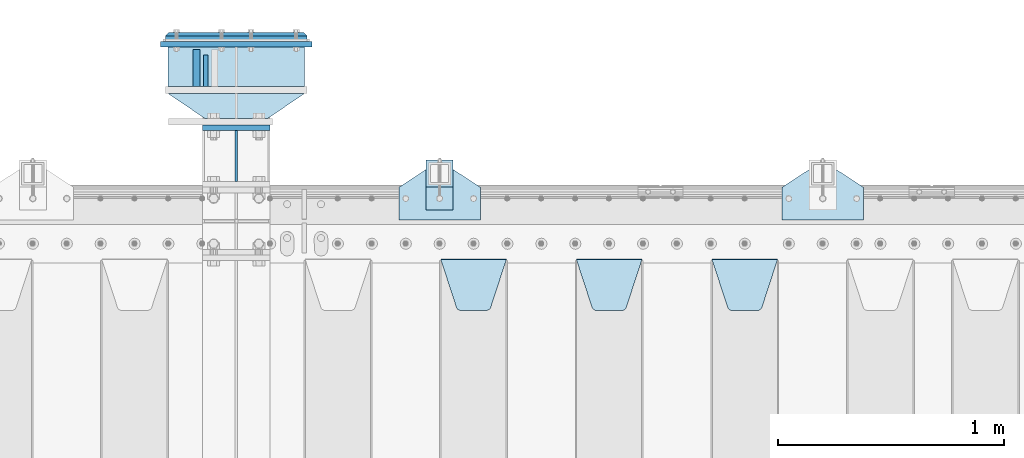
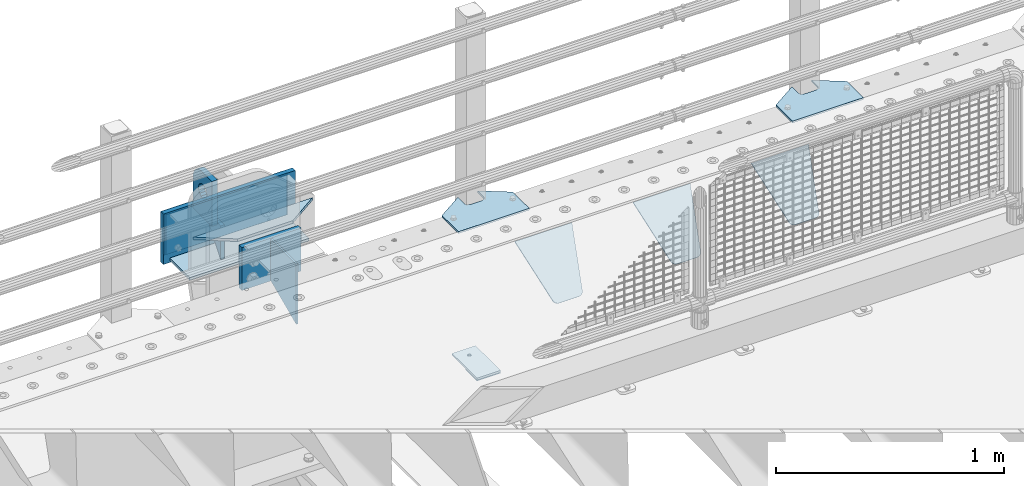
# One storey, part 187 of 208: 15 plates.
"""IFC2X3 building model written with IfcOpenShell, lengths in millimetres."""

from ifc_helpers import new_model, si_unit, frame, origin_with_axes, place, context, subcontext, project, spatial, faceted_brep, material, type_object, element, save


model = new_model("IFC2X3")

# Units and contexts
model_context = context("Model", 3, precision=1e-05, world=origin_with_axes())
body_context = subcontext(model_context, "Body", "Model", "MODEL_VIEW")
ifc_project = project(units=[si_unit("LENGTHUNIT", "METRE", prefix="MILLI"), si_unit("AREAUNIT", "SQUARE_METRE"), si_unit("VOLUMEUNIT", "CUBIC_METRE"), si_unit("MASSUNIT", "GRAM", prefix="KILO"), si_unit("TIMEUNIT", "SECOND"), si_unit("PLANEANGLEUNIT", "RADIAN"), si_unit("SOLIDANGLEUNIT", "STERADIAN"), si_unit("THERMODYNAMICTEMPERATUREUNIT", "DEGREE_CELSIUS"), si_unit("LUMINOUSINTENSITYUNIT", "LUMEN")], contexts=[model_context])

# Site, building, storey
site_placement = place(None, origin_with_axes())
site = spatial("IfcSite", under=ifc_project, at=site_placement, CompositionType="ELEMENT")
building_placement = place(site_placement, origin_with_axes())
building = spatial("IfcBuilding", under=site, at=building_placement, Name="Standard", CompositionType="ELEMENT")
storey_placement = place(building_placement, origin_with_axes())
storey = spatial("IfcBuildingStorey", under=building, at=storey_placement, Name="Undefined", CompositionType="ELEMENT", Elevation=0.0)

# Plates
ifc_material_1 = material(Name="STEEL/S355N")
plate_type_1 = type_object("IfcPlateType", PredefinedType="NOTDEFINED")
plate_1_placement = place(storey_placement, frame((-30335.5000000603, 6735.00000003457, -14.0000182219624), z_axis=(0.0, 0.0, -1.0), x_axis=(0.0, -1.0, 0.0)))
element("IfcPlate", 1, at=plate_1_placement, inside=storey, type_object=plate_type_1, material=ifc_material_1, context=body_context, shape_type="Brep", body=[
    faceted_brep([(0.0, -10.0, 0.0), (140.0, -10.0, 180.0), (140.0, 10.0, 180.0), (0.0, 10.0, 0.0), (140.0, -10.0, -1.81898940354586e-12), (140.0, 10.0, -1.81898940354586e-12)], [[[0, 1, 2, 3]], [[1, 4, 5, 2]], [[4, 0, 3, 5]], [[5, 3, 2]], [[4, 1, 0]]]),
])
plate_type_2 = type_object("IfcPlateType", PredefinedType="NOTDEFINED")
plate_2_placement = place(storey_placement, frame((-30375.5000000603, 6595.00000003457, -1.82219914677262e-05), z_axis=(0.0, 1.0, 0.0), x_axis=(0.0, 0.0, 1.0)))
element("IfcPlate", 2, at=plate_2_placement, inside=storey, type_object=plate_type_2, material=ifc_material_1, context=body_context, shape_type="Brep", body=[
    faceted_brep([(113.837049096103, -14.9999989400749, 106.162951053903), (113.837049096103, 15.0000010599251, 106.162950753903), (125.840713002497, 15.0000011401316, 114.183542552919), (125.840713002497, -14.9999988598684, 114.183542852919), (105.816457297088, -14.99999906011, 94.1592871475093), (105.816457297088, 15.00000093989, 94.1592868475093), (103.000000000005, -14.9999992017038, 80.000000150001), (103.000000000005, 15.0000007982962, 79.999999850001), (105.816457297088, -14.9999993432975, 65.8407131524926), (105.816457297088, 15.0000006567025, 65.8407128524926), (113.837049096103, -14.9999994633326, 53.8370492460988), (113.837049096103, 15.0000005366674, 53.8370489460988), (125.840713002497, -14.9999995435392, 45.8164574470834), (125.840713002497, 15.0000004564608, 45.8164571470834), (140.000000000005, -14.9999995717044, 43.000000150001), (140.000000000005, 15.0000004282956, 42.999999850001), (154.159286997514, -14.9999995435392, 45.8164574470834), (154.159286997514, 15.0000004564608, 45.8164571470834), (166.162950903908, -14.9999994633326, 53.8370492460988), (166.162950903908, 15.0000005366674, 53.8370489460988), (174.183542702923, -14.9999993432975, 65.8407131524928), (174.183542702923, 15.0000006567025, 65.8407128524927), (177.000000000005, -14.9999992017038, 80.000000150001), (177.000000000005, 15.0000007982962, 79.999999850001), (174.183542702923, -14.99999906011, 94.1592871475093), (174.183542702923, 15.00000093989, 94.1592868475093), (166.162950903908, -14.9999989400749, 106.162951053903), (166.162950903908, 15.0000010599251, 106.162950753903), (154.159286997514, -14.9999988598684, 114.183542852919), (154.159286997514, 15.0000011401316, 114.183542552919), (140.000000000005, -14.9999988317031, 117.000000150001), (140.000000000005, 15.0000011682969, 116.999999850001), (-1.40620068123098e-06, -15.0, 165.0), (170.0, -15.0, 165.0), (170.0, 15.0, 165.0), (-1.40620068123098e-06, 15.0, 165.0), (188.117333157176, -15.0, 162.614807840235), (188.117333157176, 15.0, 162.614807840235), (205.0, -15.0, 155.621778264911), (205.0, 15.0, 155.621778264911), (219.497474683058, -15.0, 144.497474683058), (219.497474683058, 15.0, 144.497474683058), (230.621778264911, -15.0, 130.0), (230.621778264911, 15.0, 130.0), (237.614807840235, -15.0, 113.117333157177), (237.614807840235, 15.0, 113.117333157177), (240.0, -15.0, 95.0), (240.0, 15.0, 95.0), (240.000015258789, -14.9999999999964, -2.06341610464733e-10), (240.000015258789, 15.0000000000036, -2.06341610464733e-10), (0.0, -15.0, 0.0), (0.0, 15.0, 0.0)], [[[0, 1, 2, 3]], [[4, 5, 1, 0]], [[6, 7, 5, 4]], [[8, 9, 7, 6]], [[10, 11, 9, 8]], [[12, 13, 11, 10]], [[14, 15, 13, 12]], [[16, 17, 15, 14]], [[18, 19, 17, 16]], [[20, 21, 19, 18]], [[22, 23, 21, 20]], [[24, 25, 23, 22]], [[26, 27, 25, 24]], [[28, 29, 27, 26]], [[30, 31, 29, 28]], [[3, 2, 31, 30]], [[32, 33, 34, 35]], [[33, 36, 37, 34]], [[36, 38, 39, 37]], [[38, 40, 41, 39]], [[40, 42, 43, 41]], [[42, 44, 45, 43]], [[44, 46, 47, 45]], [[46, 48, 49, 47]], [[48, 50, 51, 49]], [[34, 37, 39, 41, 43, 45, 47, 49, 51, 35], [19, 21, 23, 25, 27, 29, 31, 2, 1, 5, 7, 9, 11, 13, 15, 17]], [[50, 32, 35, 51]], [[48, 46, 44, 42, 40, 38, 36, 33, 32, 50], [10, 8, 6, 4, 0, 3, 30, 28, 26, 24, 22, 20, 18, 16, 14, 12]]]),
])
plate_type_3 = type_object("IfcPlateType", PredefinedType="NOTDEFINED")
plate_3_placement = place(storey_placement, frame((-28095.0, 5831.76776695596, -1.76776695296758), z_axis=(0.0, -0.707106781186548, -0.707106781186547), x_axis=(1.0, 0.0, 0.0)))
element("IfcPlate", 3, at=plate_3_placement, inside=storey, type_object=plate_type_3, material=ifc_material_1, context=body_context, shape_type="Brep", body=[
    faceted_brep([(0.0, -2.5, 0.0), (69.345504679477, -2.5, 300.17173142483), (69.345504679477, 2.5, 300.17173142483), (0.0, 2.5, 0.0), (70.9274061199576, -2.5, 304.897442415399), (70.9274061199576, 2.5, 304.8974424154), (73.3818627772307, -2.5, 309.234538108527), (73.3818627772307, 2.5, 309.234538108527), (76.6187032999551, -2.5, 313.023683126103), (76.6187032999551, 2.5, 313.023683126103), (80.5190132704993, -2.5, 316.125672595371), (80.5190132704993, 2.5, 316.125672595371), (84.9395038596849, -2.5, 318.426546230476), (84.9395038596849, 2.50000000000091, 318.426546230476), (89.7177759439219, -2.5, 319.841774983275), (89.7177759439219, 2.50000000000091, 319.841774983275), (94.678286292652, -2.49999999999909, 320.319366455078), (94.678286292652, 2.5, 320.319366455078), (195.321713707348, -2.49999999999909, 320.319366455078), (195.321713707348, 2.5, 320.319366455078), (200.282224056078, -2.5, 319.841774983275), (200.282224056078, 2.5, 319.841774983274), (205.060496140315, -2.5, 318.426546230475), (205.060496140315, 2.5, 318.426546230475), (209.480986729501, -2.5, 316.125672595371), (209.480986729501, 2.50000000000091, 316.125672595371), (213.381296700045, -2.5, 313.023683126102), (213.381296700045, 2.5, 313.023683126102), (216.618137222769, -2.5, 309.234538108526), (216.618137222769, 2.5, 309.234538108527), (219.072593880042, -2.5, 304.897442415399), (219.072593880042, 2.5, 304.897442415399), (220.654495320523, -2.5, 300.17173142483), (220.654495320523, 2.5, 300.17173142483), (290.0, -2.5, 0.0), (290.0, 2.5, 0.0)], [[[0, 1, 2, 3]], [[1, 4, 5, 2]], [[4, 6, 7, 5]], [[6, 8, 9, 7]], [[8, 10, 11, 9]], [[10, 12, 13, 11]], [[12, 14, 15, 13]], [[14, 16, 17, 15]], [[16, 18, 19, 17]], [[18, 20, 21, 19]], [[20, 22, 23, 21]], [[22, 24, 25, 23]], [[24, 26, 27, 25]], [[26, 28, 29, 27]], [[28, 30, 31, 29]], [[30, 32, 33, 31]], [[32, 34, 35, 33]], [[34, 0, 3, 35]], [[5, 7, 9, 11, 13, 15, 17, 19, 21, 23, 25, 27, 29, 31, 33, 35, 3, 2]], [[34, 32, 30, 28, 26, 24, 22, 20, 18, 16, 14, 12, 10, 8, 6, 4, 1, 0]]]),
])
plate_4_placement = place(storey_placement, frame((-28695.0, 5831.76776695596, -1.76776695296758), z_axis=(0.0, -0.707106781186548, -0.707106781186547), x_axis=(1.0, 0.0, 0.0)))
element("IfcPlate", 4, at=plate_4_placement, inside=storey, type_object=plate_type_3, material=ifc_material_1, context=body_context, shape_type="Brep", body=[
    faceted_brep([(0.0, -2.5, 0.0), (69.345504679477, -2.5, 300.17173142483), (69.345504679477, 2.5, 300.17173142483), (0.0, 2.5, 0.0), (70.9274061199576, -2.5, 304.897442415399), (70.9274061199576, 2.5, 304.8974424154), (73.3818627772307, -2.5, 309.234538108527), (73.3818627772307, 2.5, 309.234538108527), (76.6187032999551, -2.5, 313.023683126103), (76.6187032999551, 2.5, 313.023683126103), (80.5190132704993, -2.5, 316.125672595371), (80.5190132704993, 2.5, 316.125672595371), (84.9395038596849, -2.5, 318.426546230476), (84.9395038596849, 2.50000000000091, 318.426546230476), (89.7177759439219, -2.5, 319.841774983275), (89.7177759439219, 2.50000000000091, 319.841774983275), (94.678286292652, -2.49999999999909, 320.319366455078), (94.678286292652, 2.5, 320.319366455078), (195.321713707348, -2.49999999999909, 320.319366455078), (195.321713707348, 2.5, 320.319366455078), (200.282224056078, -2.5, 319.841774983275), (200.282224056078, 2.5, 319.841774983274), (205.060496140315, -2.5, 318.426546230475), (205.060496140315, 2.5, 318.426546230475), (209.480986729501, -2.5, 316.125672595371), (209.480986729501, 2.50000000000091, 316.125672595371), (213.381296700045, -2.5, 313.023683126102), (213.381296700045, 2.5, 313.023683126102), (216.618137222769, -2.5, 309.234538108526), (216.618137222769, 2.5, 309.234538108527), (219.072593880042, -2.5, 304.897442415399), (219.072593880042, 2.5, 304.897442415399), (220.654495320523, -2.5, 300.17173142483), (220.654495320523, 2.5, 300.17173142483), (290.0, -2.5, 0.0), (290.0, 2.5, 0.0)], [[[0, 1, 2, 3]], [[1, 4, 5, 2]], [[4, 6, 7, 5]], [[6, 8, 9, 7]], [[8, 10, 11, 9]], [[10, 12, 13, 11]], [[12, 14, 15, 13]], [[14, 16, 17, 15]], [[16, 18, 19, 17]], [[18, 20, 21, 19]], [[20, 22, 23, 21]], [[22, 24, 25, 23]], [[24, 26, 27, 25]], [[26, 28, 29, 27]], [[28, 30, 31, 29]], [[30, 32, 33, 31]], [[32, 34, 35, 33]], [[34, 0, 3, 35]], [[5, 7, 9, 11, 13, 15, 17, 19, 21, 23, 25, 27, 29, 31, 33, 35, 3, 2]], [[34, 32, 30, 28, 26, 24, 22, 20, 18, 16, 14, 12, 10, 8, 6, 4, 1, 0]]]),
])
plate_5_placement = place(storey_placement, frame((-29295.0, 5831.76776695596, -1.76776695296758), z_axis=(0.0, -0.707106781186548, -0.707106781186547), x_axis=(1.0, 0.0, 0.0)))
element("IfcPlate", 5, at=plate_5_placement, inside=storey, type_object=plate_type_3, material=ifc_material_1, context=body_context, shape_type="Brep", body=[
    faceted_brep([(0.0, -2.5, 0.0), (69.345504679477, -2.5, 300.17173142483), (69.345504679477, 2.5, 300.17173142483), (0.0, 2.5, 0.0), (70.9274061199576, -2.5, 304.897442415399), (70.9274061199576, 2.5, 304.8974424154), (73.3818627772307, -2.5, 309.234538108527), (73.3818627772307, 2.5, 309.234538108527), (76.6187032999551, -2.5, 313.023683126103), (76.6187032999551, 2.5, 313.023683126103), (80.5190132704993, -2.5, 316.125672595371), (80.5190132704993, 2.5, 316.125672595371), (84.9395038596849, -2.5, 318.426546230476), (84.9395038596849, 2.50000000000091, 318.426546230476), (89.7177759439219, -2.5, 319.841774983275), (89.7177759439219, 2.50000000000091, 319.841774983275), (94.678286292652, -2.49999999999909, 320.319366455078), (94.678286292652, 2.5, 320.319366455078), (195.321713707348, -2.49999999999909, 320.319366455078), (195.321713707348, 2.5, 320.319366455078), (200.282224056078, -2.5, 319.841774983275), (200.282224056078, 2.5, 319.841774983274), (205.060496140315, -2.5, 318.426546230475), (205.060496140315, 2.5, 318.426546230475), (209.480986729501, -2.5, 316.125672595371), (209.480986729501, 2.50000000000091, 316.125672595371), (213.381296700045, -2.5, 313.023683126102), (213.381296700045, 2.5, 313.023683126102), (216.618137222769, -2.5, 309.234538108526), (216.618137222769, 2.5, 309.234538108527), (219.072593880042, -2.5, 304.897442415399), (219.072593880042, 2.5, 304.897442415399), (220.654495320523, -2.5, 300.17173142483), (220.654495320523, 2.5, 300.17173142483), (290.0, -2.5, 0.0), (290.0, 2.5, 0.0)], [[[0, 1, 2, 3]], [[1, 4, 5, 2]], [[4, 6, 7, 5]], [[6, 8, 9, 7]], [[8, 10, 11, 9]], [[10, 12, 13, 11]], [[12, 14, 15, 13]], [[14, 16, 17, 15]], [[16, 18, 19, 17]], [[18, 20, 21, 19]], [[20, 22, 23, 21]], [[22, 24, 25, 23]], [[24, 26, 27, 25]], [[26, 28, 29, 27]], [[28, 30, 31, 29]], [[30, 32, 33, 31]], [[32, 34, 35, 33]], [[34, 0, 3, 35]], [[5, 7, 9, 11, 13, 15, 17, 19, 21, 23, 25, 27, 29, 31, 33, 35, 3, 2]], [[34, 32, 30, 28, 26, 24, 22, 20, 18, 16, 14, 12, 10, 8, 6, 4, 1, 0]]]),
])
ifc_material_2 = material(Name="STEEL/S355J2")
plate_type_4 = type_object("IfcPlateType", PredefinedType="NOTDEFINED")
plate_6_placement = place(storey_placement, frame((-27785.0, 6005.0, 5.00000000004911), z_axis=(0.0, 1.0, 0.0), x_axis=(1.0, 0.0, 0.0)))
element("IfcPlate", 6, at=plate_6_placement, inside=storey, type_object=plate_type_4, material=ifc_material_2, context=body_context, shape_type="Brep", body=[
    faceted_brep([(0.0, -5.0, 0.0), (2.31396552408114e-06, -5.0, 145.0), (2.31396552408114e-06, 5.0, 145.0), (0.0, 5.0, 0.0), (130.0, -5.0, 230.0), (130.0, 5.0, 230.0), (130.0, -5.0, 180.0), (130.0, 5.0, 180.0), (130.48036798992, -5.0, 175.122741949597), (130.48036798992, 5.0, 175.122741949597), (131.903011687216, -5.0, 170.432914190873), (131.903011687216, 5.0, 170.432914190873), (134.213259692435, -5.0, 166.11074417451), (134.213259692435, 5.0, 166.11074417451), (137.322330470335, -5.0, 162.322330470336), (137.322330470335, 5.0, 162.322330470336), (141.110744174512, -5.0, 159.213259692437), (141.110744174512, 5.0, 159.213259692437), (145.432914190871, -5.0, 156.903011687218), (145.432914190871, 5.0, 156.903011687218), (150.122741949595, -5.0, 155.48036798992), (150.122741949595, 5.0, 155.48036798992), (155.0, -5.0, 155.0), (155.0, 5.0, 155.0), (205.0, -5.0, 155.0), (205.0, 5.0, 155.0), (209.877258050405, -5.0, 155.48036798992), (209.877258050405, 5.0, 155.48036798992), (214.567085809129, -5.0, 156.903011687218), (214.567085809129, 5.0, 156.903011687218), (218.889255825488, -5.0, 159.213259692437), (218.889255825488, 5.0, 159.213259692437), (222.677669529665, -5.0, 162.322330470336), (222.677669529665, 5.0, 162.322330470336), (225.786740307565, -5.0, 166.11074417451), (225.786740307565, 5.0, 166.11074417451), (228.096988312784, -5.0, 170.432914190873), (228.096988312784, 5.0, 170.432914190873), (229.51963201008, -5.0, 175.122741949597), (229.51963201008, 5.0, 175.122741949597), (230.0, -5.0, 180.0), (230.0, 5.0, 180.0), (230.0, -5.0, 230.0), (230.0, 5.0, 230.0), (360.0, -5.0, 145.0), (360.0, 5.0, 145.0), (360.0, -5.0, -7.27595761418343e-12), (360.0, 5.0, -7.27595761418343e-12)], [[[0, 1, 2, 3]], [[1, 4, 5, 2]], [[4, 6, 7, 5]], [[6, 8, 9, 7]], [[8, 10, 11, 9]], [[10, 12, 13, 11]], [[12, 14, 15, 13]], [[14, 16, 17, 15]], [[16, 18, 19, 17]], [[18, 20, 21, 19]], [[20, 22, 23, 21]], [[22, 24, 25, 23]], [[24, 26, 27, 25]], [[26, 28, 29, 27]], [[28, 30, 31, 29]], [[30, 32, 33, 31]], [[32, 34, 35, 33]], [[34, 36, 37, 35]], [[36, 38, 39, 37]], [[38, 40, 41, 39]], [[40, 42, 43, 41]], [[42, 44, 45, 43]], [[44, 46, 47, 45]], [[46, 0, 3, 47]], [[5, 7, 9, 11, 13, 15, 17, 19, 21, 23, 25, 27, 29, 31, 33, 35, 37, 39, 41, 43, 45, 47, 3, 2]], [[46, 44, 42, 40, 38, 36, 34, 32, 30, 28, 26, 24, 22, 20, 18, 16, 14, 12, 10, 8, 6, 4, 1, 0]]]),
])
plate_7_placement = place(storey_placement, frame((-29480.0, 6005.0, 5.00000000004911), z_axis=(0.0, 1.0, 0.0), x_axis=(1.0, 0.0, 0.0)))
element("IfcPlate", 7, at=plate_7_placement, inside=storey, type_object=plate_type_4, material=ifc_material_2, context=body_context, shape_type="Brep", body=[
    faceted_brep([(0.0, -5.0, 0.0), (2.31396552408114e-06, -5.0, 145.0), (2.31396552408114e-06, 5.0, 145.0), (0.0, 5.0, 0.0), (130.0, -5.0, 230.0), (130.0, 5.0, 230.0), (130.0, -5.0, 180.0), (130.0, 5.0, 180.0), (130.48036798992, -5.0, 175.122741949597), (130.48036798992, 5.0, 175.122741949597), (131.903011687216, -5.0, 170.432914190873), (131.903011687216, 5.0, 170.432914190873), (134.213259692435, -5.0, 166.11074417451), (134.213259692435, 5.0, 166.11074417451), (137.322330470335, -5.0, 162.322330470336), (137.322330470335, 5.0, 162.322330470336), (141.110744174512, -5.0, 159.213259692437), (141.110744174512, 5.0, 159.213259692437), (145.432914190871, -5.0, 156.903011687218), (145.432914190871, 5.0, 156.903011687218), (150.122741949595, -5.0, 155.48036798992), (150.122741949595, 5.0, 155.48036798992), (155.0, -5.0, 155.0), (155.0, 5.0, 155.0), (205.0, -5.0, 155.0), (205.0, 5.0, 155.0), (209.877258050405, -5.0, 155.48036798992), (209.877258050405, 5.0, 155.48036798992), (214.567085809129, -5.0, 156.903011687218), (214.567085809129, 5.0, 156.903011687218), (218.889255825488, -5.0, 159.213259692437), (218.889255825488, 5.0, 159.213259692437), (222.677669529665, -5.0, 162.322330470336), (222.677669529665, 5.0, 162.322330470336), (225.786740307565, -5.0, 166.11074417451), (225.786740307565, 5.0, 166.11074417451), (228.096988312784, -5.0, 170.432914190873), (228.096988312784, 5.0, 170.432914190873), (229.51963201008, -5.0, 175.122741949597), (229.51963201008, 5.0, 175.122741949597), (230.0, -5.0, 180.0), (230.0, 5.0, 180.0), (230.0, -5.0, 230.0), (230.0, 5.0, 230.0), (360.0, -5.0, 145.0), (360.0, 5.0, 145.0), (360.0, -5.0, -7.27595761418343e-12), (360.0, 5.0, -7.27595761418343e-12)], [[[0, 1, 2, 3]], [[1, 4, 5, 2]], [[4, 6, 7, 5]], [[6, 8, 9, 7]], [[8, 10, 11, 9]], [[10, 12, 13, 11]], [[12, 14, 15, 13]], [[14, 16, 17, 15]], [[16, 18, 19, 17]], [[18, 20, 21, 19]], [[20, 22, 23, 21]], [[22, 24, 25, 23]], [[24, 26, 27, 25]], [[26, 28, 29, 27]], [[28, 30, 31, 29]], [[30, 32, 33, 31]], [[32, 34, 35, 33]], [[34, 36, 37, 35]], [[36, 38, 39, 37]], [[38, 40, 41, 39]], [[40, 42, 43, 41]], [[42, 44, 45, 43]], [[44, 46, 47, 45]], [[46, 0, 3, 47]], [[5, 7, 9, 11, 13, 15, 17, 19, 21, 23, 25, 27, 29, 31, 33, 35, 37, 39, 41, 43, 45, 47, 3, 2]], [[46, 44, 42, 40, 38, 36, 34, 32, 30, 28, 26, 24, 22, 20, 18, 16, 14, 12, 10, 8, 6, 4, 1, 0]]]),
])
plate_type_5 = type_object("IfcPlateType", PredefinedType="NOTDEFINED")
plate_8_placement = place(storey_placement, frame((-29359.9999999999, 6050.00000000021, -850.000000000002), z_axis=(0.0, 1.0, 0.0), x_axis=(1.0, 0.0, 0.0)))
element("IfcPlate", 8, at=plate_8_placement, inside=storey, type_object=plate_type_5, material=ifc_material_2, context=body_context, shape_type="Brep", body=[
    faceted_brep([(66.3639610305399, -5.0, 163.636038969112), (66.3639610305399, 5.0, 163.636038969112), (59.9999999998618, 5.0, 160.999999999791), (59.9999999998618, -5.0, 160.999999999791), (53.6360389691836, 5.0, 163.636038969112), (53.6360389691836, -5.0, 163.636038969112), (50.9999999998618, 5.0, 169.999999999791), (50.9999999998618, -5.0, 169.999999999791), (53.6360389691836, 5.0, 176.36396103047), (53.6360389691836, -5.0, 176.36396103047), (59.9999999998618, 5.0, 178.999999999791), (59.9999999998618, -5.0, 178.999999999791), (66.3639610305399, 5.0, 176.36396103047), (66.3639610305399, -5.0, 176.36396103047), (68.9999999998618, 5.0, 169.999999999791), (68.9999999998618, -5.0, 169.999999999791), (120.0, -5.0, 0.0), (120.0, -5.0, 220.0), (0.0, -5.0, 220.0), (0.0, -5.0, 0.0), (0.0, 5.0, 0.0), (120.0, 5.0, 0.0), (120.0, 5.0, 220.0), (0.0, 5.0, 220.0)], [[[0, 1, 2, 3]], [[3, 2, 4, 5]], [[5, 4, 6, 7]], [[7, 6, 8, 9]], [[9, 8, 10, 11]], [[11, 10, 12, 13]], [[13, 12, 14, 15]], [[15, 14, 1, 0]], [[16, 17, 18, 19], [3, 5, 7, 9, 11, 13, 15, 0]], [[16, 19, 20, 21]], [[17, 16, 21, 22]], [[18, 17, 22, 23]], [[19, 18, 23, 20]], [[22, 21, 20, 23], [10, 8, 6, 4, 2, 1, 14, 12]]]),
])
plate_type_6 = type_object("IfcPlateType", PredefinedType="NOTDEFINED")
plate_9_placement = place(storey_placement, frame((-29359.9999999999, 6050.00000000021, -857.500000000002), z_axis=(0.0, 1.0, 0.0), x_axis=(1.0, 0.0, 0.0)))
element("IfcPlate", 9, at=plate_9_placement, inside=storey, type_object=plate_type_6, material=ifc_material_2, context=body_context, shape_type="Brep", body=[
    faceted_brep([(0.0, -2.5, 0.0), (0.0, -2.5, 100.0), (0.0, 2.5, 100.0), (0.0, 2.5, 0.0), (120.0, -2.5, 100.0), (120.0, 2.5, 100.0), (120.0, -2.5, 0.0), (120.0, 2.5, 0.0)], [[[0, 1, 2, 3]], [[1, 4, 5, 2]], [[4, 6, 7, 5]], [[6, 0, 3, 7]], [[5, 7, 3, 2]], [[6, 4, 1, 0]]]),
])
ifc_material_3 = material()
plate_type_7 = type_object("IfcPlateType", PredefinedType="NOTDEFINED")
plate_10_placement = place(storey_placement, frame((-29897.5000000603, 6595.00000003457, -243.000018221991), z_axis=(0.0, 1.0, 0.0), x_axis=(-1.0, 0.0, 0.0)))
element("IfcPlate", 10, at=plate_10_placement, inside=storey, type_object=plate_type_7, material=ifc_material_3, context=body_context, shape_type="Brep", body=[
    faceted_brep([(0.0, -7.0, 0.0), (0.0, -7.0, 175.0), (0.0, 7.0, 175.0), (0.0, 7.0, 0.0), (605.0, -7.0, 175.0), (605.0, 7.0, 175.0), (605.0, -7.0, 0.0), (605.0, 7.0, 0.0)], [[[0, 1, 2, 3]], [[1, 4, 5, 2]], [[4, 6, 7, 5]], [[6, 0, 3, 7]], [[5, 7, 3, 2]], [[6, 4, 1, 0]]]),
])
plate_type_8 = type_object("IfcPlateType", PredefinedType="NOTDEFINED")
plate_11_placement = place(storey_placement, frame((-29897.5000000603, 6565.00000003457, -7.00001822199147), z_axis=(-0.560566412034006, 0.828109472050236, 0.0), x_axis=(-0.828109472050233, -0.560566412034011, 0.0)))
element("IfcPlate", 11, at=plate_11_placement, inside=storey, type_object=plate_type_8, material=ifc_material_1, context=body_context, shape_type="Brep", body=[
    faceted_brep([(0.0, -7.0, 0.0), (501.006225585941, -7.0, 339.142669677734), (501.006225585941, 7.0, 339.142669677734), (0.0, 7.0, 0.0), (428.100738525394, -7.0, 156.958602905273), (428.100738525394, 7.0, 156.958602905273), (196.230087280273, -7.0, 3.05590219795704e-10), (196.230087280273, 7.0, 3.05590219795704e-10)], [[[0, 1, 2, 3]], [[1, 4, 5, 2]], [[4, 6, 7, 5]], [[6, 0, 3, 7]], [[5, 7, 3, 2]], [[6, 4, 1, 0]]]),
])
plate_type_9 = type_object("IfcPlateType", PredefinedType="NOTDEFINED")
plate_12_placement = place(storey_placement, frame((-30350.0000000603, 6412.50000003457, -240.000018221991), z_axis=(0.0, 0.0, 1.0), x_axis=(1.0, 0.0, 0.0)))
element("IfcPlate", 12, at=plate_12_placement, inside=storey, type_object=plate_type_9, material=ifc_material_1, context=body_context, shape_type="Brep", body=[
    faceted_brep([(0.0, -12.5, 0.0), (0.0, -12.5, 230.0), (0.0, 12.5, 230.0), (0.0, 12.5, 0.0), (300.0, -12.5, 230.0), (300.0, 12.5, 230.0), (300.0, -12.5, 0.0), (300.0, 12.5, 0.0)], [[[0, 1, 2, 3]], [[1, 4, 5, 2]], [[4, 6, 7, 5]], [[6, 0, 3, 7]], [[5, 7, 3, 2]], [[6, 4, 1, 0]]]),
])
ifc_material_4 = material()
plate_type_10 = type_object("IfcPlateType", PredefinedType="NOTDEFINED")
plate_13_placement = place(storey_placement, frame((-29887.5000000603, 6815.00000003457, -12.5000182219915), z_axis=(0.0, 0.0, -1.0), x_axis=(-1.0, 0.0, 0.0)))
element("IfcPlate", 13, at=plate_13_placement, inside=storey, type_object=plate_type_10, material=ifc_material_4, context=body_context, shape_type="Brep", body=[
    faceted_brep([(0.0, -15.0, 0.0), (5.0, -20.0, 5.0), (5.0, -20.0, 220.0), (0.0, -15.0, 225.0), (625.0, -15.0, 0.0), (620.0, -20.0, 5.0), (620.0, -20.0, 220.0), (625.0, -15.0, 225.0), (15.0, 20.0, 15.0), (0.0, 5.0, 0.0), (0.0, 5.0, 225.0), (15.0, 20.0, 210.0), (625.0, 4.99999999999818, 225.0), (610.0, 20.0, 210.0), (625.0, 5.0, 0.0), (610.0, 20.0, 15.0), (64.8205080756888, -5.0, 37.5), (57.5, -5.0, 30.1794919243112), (47.5, -5.0, 27.5), (37.5, -5.0, 30.1794919243112), (30.1794919243112, -5.0, 37.5), (27.5, -5.0, 47.5), (30.1794919243112, -5.0, 57.5), (37.5, -5.0, 64.8205080756888), (47.5, -5.0, 67.5), (57.5, -5.0, 64.8205080756888), (64.8205080756888, -5.0, 57.5), (67.5, -5.0, 47.5), (37.5, 20.0, 64.8205080756888), (30.1794919243112, 20.0, 57.5), (47.5, 20.0, 67.5), (57.5, 20.0, 64.8205080756888), (64.8205080756888, 20.0, 57.5), (67.5, 20.0, 47.5), (64.8205080756888, 20.0, 37.5), (57.5, 20.0, 30.1794919243112), (47.5, 20.0, 27.5), (37.5, 20.0, 30.1794919243112), (30.1794919243112, 20.0, 37.5), (27.5, 20.0, 47.5), (264.820508075689, -5.0, 37.5), (257.5, -5.0, 30.1794919243112), (247.5, -5.0, 27.5), (237.5, -5.0, 30.1794919243112), (230.179491924311, -5.0, 37.5), (227.5, -5.0, 47.5), (230.179491924311, -5.0, 57.5), (237.5, -5.0, 64.8205080756888), (247.5, -5.0, 67.5), (257.5, -5.0, 64.8205080756888), (264.820508075689, -5.0, 57.5), (267.5, -5.0, 47.5), (230.179491924311, 20.0, 57.5), (227.5, 20.0, 47.5), (237.5, 20.0, 64.8205080756888), (247.5, 20.0, 67.5), (257.5, 20.0, 64.8205080756888), (264.820508075689, 20.0, 57.5), (267.5, 20.0, 47.5), (264.820508075689, 20.0, 37.5), (257.5, 20.0, 30.1794919243112), (247.5, 20.0, 27.5), (237.5, 20.0, 30.1794919243112), (230.179491924311, 20.0, 37.5), (594.820508075689, -5.0, 37.5), (587.5, -5.0, 30.1794919243112), (577.5, -5.0, 27.5), (567.5, -5.0, 30.1794919243112), (560.179491924311, -5.0, 37.5), (557.5, -5.0, 47.5), (560.179491924311, -5.0, 57.5), (567.5, -5.0, 64.8205080756888), (577.5, -5.0, 67.5), (587.5, -5.0, 64.8205080756888), (594.820508075689, -5.0, 57.5), (597.5, -5.0, 47.5), (560.179491924311, 20.0, 57.5), (557.5, 20.0, 47.5), (567.5, 20.0, 64.8205080756888), (577.5, 20.0, 67.5), (587.5, 20.0, 64.8205080756888), (594.820508075689, 20.0, 57.5), (597.5, 20.0, 47.5), (594.820508075689, 20.0, 37.5), (587.5, 20.0, 30.1794919243112), (577.5, 20.0, 27.5), (567.5, 20.0, 30.1794919243112), (560.179491924311, 20.0, 37.5), (594.820508075689, -5.0, 167.5), (587.5, -5.0, 160.179491924311), (577.5, -5.0, 157.5), (567.5, -5.0, 160.179491924311), (560.179491924311, -5.0, 167.5), (557.5, -5.0, 177.5), (560.179491924311, -5.0, 187.5), (567.5, -5.0, 194.820508075689), (577.5, -5.0, 197.5), (587.5, -5.0, 194.820508075689), (594.820508075689, -5.0, 187.5), (597.5, -5.0, 177.5), (560.179491924311, 20.0, 187.5), (557.5, 20.0, 177.5), (567.5, 20.0, 194.820508075689), (577.5, 20.0, 197.5), (587.5, 20.0, 194.820508075689), (594.820508075689, 20.0, 187.5), (597.5, 20.0, 177.5), (594.820508075689, 20.0, 167.5), (587.5, 20.0, 160.179491924311), (577.5, 20.0, 157.5), (567.5, 20.0, 160.179491924311), (560.179491924311, 20.0, 167.5), (264.820508075689, -5.0, 167.5), (257.5, -5.0, 160.179491924311), (247.5, -5.0, 157.5), (237.5, -5.0, 160.179491924311), (230.179491924311, -5.0, 167.5), (227.5, -5.0, 177.5), (230.179491924311, -5.0, 187.5), (237.5, -5.0, 194.820508075689), (247.5, -5.0, 197.5), (257.5, -5.0, 194.820508075689), (264.820508075689, -5.0, 187.5), (267.5, -5.0, 177.5), (230.179491924311, 20.0, 187.5), (227.5, 20.0, 177.5), (237.5, 20.0, 194.820508075689), (247.5, 20.0, 197.5), (257.5, 20.0, 194.820508075689), (264.820508075689, 20.0, 187.5), (267.5, 20.0, 177.5), (264.820508075689, 20.0, 167.5), (257.5, 20.0, 160.179491924311), (247.5, 20.0, 157.5), (237.5, 20.0, 160.179491924311), (230.179491924311, 20.0, 167.5), (64.8205080756888, -5.0, 167.5), (57.5, -5.0, 160.179491924311), (47.5, -5.0, 157.5), (37.5, -5.0, 160.179491924311), (30.1794919243112, -5.0, 167.5), (27.5, -5.0, 177.5), (30.1794919243112, -5.0, 187.5), (37.5, -5.0, 194.820508075689), (47.5, -5.0, 197.5), (57.5, -5.0, 194.820508075689), (64.8205080756888, -5.0, 187.5), (67.5, -5.0, 177.5), (30.1794919243112, 20.0, 187.5), (27.5, 20.0, 177.5), (37.5, 20.0, 194.820508075689), (47.5, 20.0, 197.5), (57.5, 20.0, 194.820508075689), (64.8205080756888, 20.0, 187.5), (67.5, 20.0, 177.5), (64.8205080756888, 20.0, 167.5), (57.5, 20.0, 160.179491924311), (47.5, 20.0, 157.5), (37.5, 20.0, 160.179491924311), (30.1794919243112, 20.0, 167.5), (394.820508075689, -5.0, 167.5), (387.5, -5.0, 160.179491924311), (377.5, -5.0, 157.5), (367.5, -5.0, 160.179491924311), (360.179491924311, -5.0, 167.5), (357.5, -5.0, 177.5), (360.179491924311, -5.0, 187.5), (367.5, -5.0, 194.820508075689), (377.5, -5.0, 197.5), (387.5, -5.0, 194.820508075689), (394.820508075689, -5.0, 187.5), (397.5, -5.0, 177.5), (360.179491924311, 20.0, 187.5), (357.5, 20.0, 177.5), (367.5, 20.0, 194.820508075689), (377.5, 20.0, 197.5), (387.5, 20.0, 194.820508075689), (394.820508075689, 20.0, 187.5), (397.5, 20.0, 177.5), (394.820508075689, 20.0, 167.5), (387.5, 20.0, 160.179491924311), (377.5, 20.0, 157.5), (367.5, 20.0, 160.179491924311), (360.179491924311, 20.0, 167.5), (394.820508075689, -5.0, 37.5), (387.5, -5.0, 30.1794919243112), (377.5, -5.0, 27.5), (367.5, -5.0, 30.1794919243112), (360.179491924311, -5.0, 37.5), (357.5, -5.0, 47.5), (360.179491924311, -5.0, 57.5), (367.5, -5.0, 64.8205080756888), (377.5, -5.0, 67.5), (387.5, -5.0, 64.8205080756888), (394.820508075689, -5.0, 57.5), (397.5, -5.0, 47.5), (360.179491924311, 20.0, 57.5), (357.5, 20.0, 47.5), (367.5, 20.0, 64.8205080756888), (377.5, 20.0, 67.5), (387.5, 20.0, 64.8205080756888), (394.820508075689, 20.0, 57.5), (397.5, 20.0, 47.5), (394.820508075689, 20.0, 37.5), (387.5, 20.0, 30.1794919243112), (377.5, 20.0, 27.5), (367.5, 20.0, 30.1794919243112), (360.179491924311, 20.0, 37.5)], [[[0, 1, 2, 3]], [[4, 5, 1, 0]], [[6, 7, 3, 2]], [[7, 6, 5, 4]], [[8, 9, 10, 11]], [[12, 13, 11, 10]], [[14, 15, 13, 12]], [[15, 14, 9, 8]], [[16, 17, 18, 19, 20, 21, 22, 23, 24, 25, 26, 27]], [[28, 23, 22, 29]], [[30, 24, 23, 28]], [[31, 25, 24, 30]], [[32, 26, 25, 31]], [[33, 27, 26, 32]], [[34, 16, 27, 33]], [[35, 17, 16, 34]], [[36, 18, 17, 35]], [[37, 19, 18, 36]], [[38, 20, 19, 37]], [[39, 21, 20, 38]], [[29, 22, 21, 39]], [[5, 6, 2, 1]], [[9, 14, 4, 0]], [[14, 12, 7, 4]], [[12, 10, 3, 7]], [[10, 9, 0, 3]], [[40, 41, 42, 43, 44, 45, 46, 47, 48, 49, 50, 51]], [[52, 46, 45, 53]], [[54, 47, 46, 52]], [[55, 48, 47, 54]], [[56, 49, 48, 55]], [[57, 50, 49, 56]], [[58, 51, 50, 57]], [[59, 40, 51, 58]], [[60, 41, 40, 59]], [[61, 42, 41, 60]], [[62, 43, 42, 61]], [[63, 44, 43, 62]], [[53, 45, 44, 63]], [[64, 65, 66, 67, 68, 69, 70, 71, 72, 73, 74, 75]], [[76, 70, 69, 77]], [[78, 71, 70, 76]], [[79, 72, 71, 78]], [[80, 73, 72, 79]], [[81, 74, 73, 80]], [[82, 75, 74, 81]], [[83, 64, 75, 82]], [[84, 65, 64, 83]], [[85, 66, 65, 84]], [[86, 67, 66, 85]], [[87, 68, 67, 86]], [[77, 69, 68, 87]], [[88, 89, 90, 91, 92, 93, 94, 95, 96, 97, 98, 99]], [[100, 94, 93, 101]], [[102, 95, 94, 100]], [[103, 96, 95, 102]], [[104, 97, 96, 103]], [[105, 98, 97, 104]], [[106, 99, 98, 105]], [[107, 88, 99, 106]], [[108, 89, 88, 107]], [[109, 90, 89, 108]], [[110, 91, 90, 109]], [[111, 92, 91, 110]], [[101, 93, 92, 111]], [[112, 113, 114, 115, 116, 117, 118, 119, 120, 121, 122, 123]], [[124, 118, 117, 125]], [[126, 119, 118, 124]], [[127, 120, 119, 126]], [[128, 121, 120, 127]], [[129, 122, 121, 128]], [[130, 123, 122, 129]], [[131, 112, 123, 130]], [[132, 113, 112, 131]], [[133, 114, 113, 132]], [[134, 115, 114, 133]], [[135, 116, 115, 134]], [[125, 117, 116, 135]], [[136, 137, 138, 139, 140, 141, 142, 143, 144, 145, 146, 147]], [[148, 142, 141, 149]], [[150, 143, 142, 148]], [[151, 144, 143, 150]], [[152, 145, 144, 151]], [[153, 146, 145, 152]], [[154, 147, 146, 153]], [[155, 136, 147, 154]], [[156, 137, 136, 155]], [[157, 138, 137, 156]], [[158, 139, 138, 157]], [[159, 140, 139, 158]], [[149, 141, 140, 159]], [[160, 161, 162, 163, 164, 165, 166, 167, 168, 169, 170, 171]], [[172, 166, 165, 173]], [[174, 167, 166, 172]], [[175, 168, 167, 174]], [[176, 169, 168, 175]], [[177, 170, 169, 176]], [[178, 171, 170, 177]], [[179, 160, 171, 178]], [[180, 161, 160, 179]], [[181, 162, 161, 180]], [[182, 163, 162, 181]], [[183, 164, 163, 182]], [[173, 165, 164, 183]], [[184, 185, 186, 187, 188, 189, 190, 191, 192, 193, 194, 195]], [[196, 190, 189, 197]], [[198, 191, 190, 196]], [[199, 192, 191, 198]], [[200, 193, 192, 199]], [[201, 194, 193, 200]], [[202, 195, 194, 201]], [[203, 184, 195, 202]], [[204, 185, 184, 203]], [[205, 186, 185, 204]], [[206, 187, 186, 205]], [[207, 188, 187, 206]], [[197, 189, 188, 207]], [[13, 15, 8, 11], [37, 36, 35, 34, 33, 32, 31, 30, 28, 29, 39, 38], [206, 205, 204, 203, 202, 201, 200, 199, 198, 196, 197, 207], [182, 181, 180, 179, 178, 177, 176, 175, 174, 172, 173, 183], [158, 157, 156, 155, 154, 153, 152, 151, 150, 148, 149, 159], [134, 133, 132, 131, 130, 129, 128, 127, 126, 124, 125, 135], [110, 109, 108, 107, 106, 105, 104, 103, 102, 100, 101, 111], [86, 85, 84, 83, 82, 81, 80, 79, 78, 76, 77, 87], [62, 61, 60, 59, 58, 57, 56, 55, 54, 52, 53, 63]]]),
])
plate_type_11 = type_object("IfcPlateType", PredefinedType="NOTDEFINED")
plate_14_placement = place(storey_placement, frame((-29865.0000000603, 6782.50000003457, 9.99998177800853), z_axis=(0.0, 0.0, -1.0), x_axis=(-1.0, 0.0, 0.0)))
element("IfcPlate", 14, at=plate_14_placement, inside=storey, type_object=plate_type_11, material=ifc_material_1, context=body_context, shape_type="Brep", body=[
    faceted_brep([(0.0, -12.5, 0.0), (0.0, -12.5, 270.0), (0.0, 12.5, 270.0), (0.0, 12.5, 0.0), (670.0, -12.5, 270.0), (670.0, 12.5, 270.0), (670.0, -12.5, 0.0), (670.0, 12.5, 0.0)], [[[0, 1, 2, 3]], [[1, 4, 5, 2]], [[4, 6, 7, 5]], [[6, 0, 3, 7]], [[5, 7, 3, 2]], [[6, 4, 1, 0]]]),
])
plate_type_12 = type_object("IfcPlateType", PredefinedType="NOTDEFINED")
plate_15_placement = place(storey_placement, frame((-30200.0000000603, 6175.00000003457, -336.000018221991), z_axis=(0.0, 1.0, 0.0), x_axis=(0.0, 0.0, 1.0)))
element("IfcPlate", 15, at=plate_15_placement, inside=storey, type_object=plate_type_12, material=ifc_material_1, context=body_context, shape_type="Brep", body=[
    faceted_brep([(0.0, -5.0, 0.0), (100.0, -5.0, 225.0), (100.0, 5.0, 225.0), (0.0, 5.0, 0.0), (322.0, -5.0, 225.0), (322.0, 5.0, 225.0), (322.0, -5.0, 0.0), (322.0, 5.0, 0.0)], [[[0, 1, 2, 3]], [[1, 4, 5, 2]], [[4, 6, 7, 5]], [[6, 0, 3, 7]], [[5, 7, 3, 2]], [[6, 4, 1, 0]]]),
])

save(model, "model.ifc")
